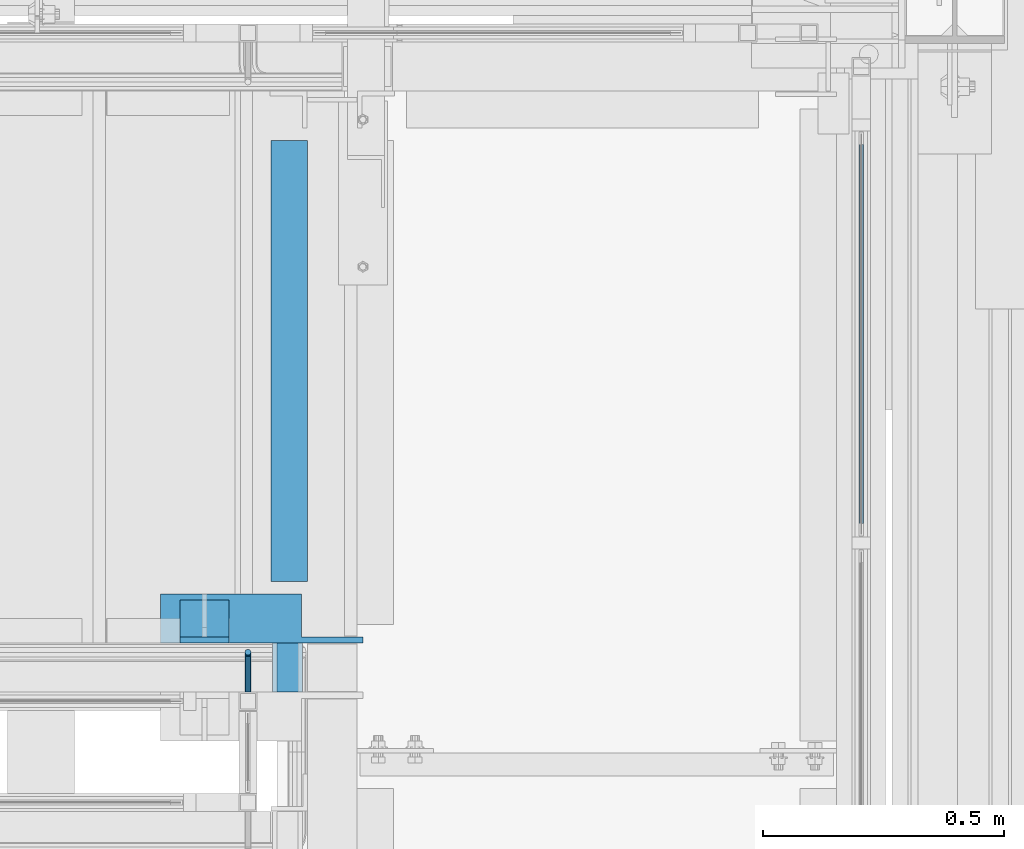
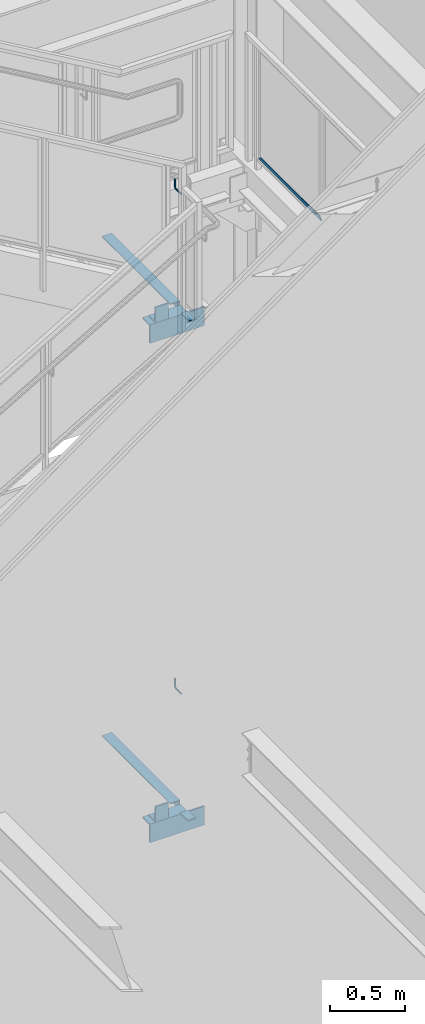
# One storey, part 947 of 1179: 11 beams, 11 elements without a shape of their own.
"""IFC2X3 building model written with IfcOpenShell, lengths in millimetres."""

from ifc_helpers import new_model, si_unit, frame, origin_with_axes, place, context, subcontext, project, spatial, faceted_brep, material, type_object, element, aggregate, save


model = new_model("IFC2X3")

# Units and contexts
model_context = context("Model", 3, precision=1e-05, world=origin_with_axes())
body_context = subcontext(model_context, "Body", "Model", "MODEL_VIEW")
ifc_project = project(units=[si_unit("LENGTHUNIT", "METRE", prefix="MILLI"), si_unit("AREAUNIT", "SQUARE_METRE"), si_unit("VOLUMEUNIT", "CUBIC_METRE"), si_unit("MASSUNIT", "GRAM", prefix="KILO"), si_unit("TIMEUNIT", "SECOND"), si_unit("PLANEANGLEUNIT", "RADIAN"), si_unit("SOLIDANGLEUNIT", "STERADIAN"), si_unit("THERMODYNAMICTEMPERATUREUNIT", "DEGREE_CELSIUS"), si_unit("LUMINOUSINTENSITYUNIT", "LUMEN")], contexts=[model_context])

# Site, building, storey
site_placement = place(None, origin_with_axes())
site = spatial("IfcSite", under=ifc_project, at=site_placement, CompositionType="ELEMENT")
building_placement = place(site_placement, origin_with_axes())
building = spatial("IfcBuilding", under=site, at=building_placement, Name="Undefined", CompositionType="ELEMENT")
storey_placement = place(building_placement, origin_with_axes())
storey = spatial("IfcBuildingStorey", under=building, at=storey_placement, Name="Undefined", CompositionType="ELEMENT", Elevation=0.0)

# Assembly, beam
assembly_1_placement = place(storey_placement, origin_with_axes())
assembly_1 = element("IfcElementAssembly", 1, at=assembly_1_placement, inside=storey, Name="GUARDRAIL", AssemblyPlace="NOTDEFINED", PredefinedType="RIGID_FRAME")
ifc_material_1 = material(Name="STEEL/BUY-OUT")
beam_type_1 = type_object("IfcBeamType", PredefinedType="NOTDEFINED")
beam_1_placement = place(assembly_1_placement, frame((24110.9502052178, 40441.9591242175, 6357.93749909944), z_axis=(0.0, 1.0, 0.0), x_axis=(0.0, 0.0, -1.0)))
beam_1 = element("IfcBeam", 2, at=beam_1_placement, type_object=beam_type_1, material=ifc_material_1, Name="U-EDGE", context=body_context, shape_type="Brep", body=[
    faceted_brep([(-5.45696821063757e-11, -4.76236513509502, -392.906500000157), (22.2249999999613, -4.76236513509502, -415.131500000178), (22.2249999999794, -1.58750000000146, -415.131500000192), (0.0, -1.58750000000146, -392.906500000216), (0.0, 1.58750000000146, -392.906500000216), (25.3999999999969, 1.58750000000146, -418.306499999999), (25.3999999999423, -7.93736513509793, -418.306499999999), (-5.45696821063757e-11, -7.93736513509793, -392.906500000157), (25.3999999999423, -7.93736513509793, 418.306499999999), (-5.45696821063757e-11, -7.93736513509793, 392.906500780409), (-5.45696821063757e-11, -4.76236513509502, 392.906500780409), (22.2249999999613, -4.76236513509502, 415.131500780422), (22.2249999999794, -1.58750000000146, 415.131500780437), (0.0, -1.58750000000146, 392.90650078046), (0.0, 1.58750000000146, 392.90650078046), (25.3999999999969, 1.58750000000146, 418.306499999999)], [[[0, 1, 2, 3, 4, 5, 6, 7]], [[7, 6, 8, 9]], [[0, 7, 9, 10]], [[1, 0, 10, 11]], [[2, 1, 11, 12]], [[3, 2, 12, 13]], [[4, 3, 13, 14]], [[5, 4, 14, 15]], [[6, 5, 15, 8]], [[14, 13, 12, 11, 10, 9, 8, 15]]]),
])
aggregate(assembly_1, [beam_1])

assembly_2_placement = place(storey_placement, origin_with_axes())
assembly_2 = element("IfcElementAssembly", 3, at=assembly_2_placement, inside=storey, Name="GUARDRAIL", AssemblyPlace="NOTDEFINED", PredefinedType="RIGID_FRAME")
ifc_material_2 = material(Name="STEEL/A36")
beam_type_2 = type_object("IfcBeamType", PredefinedType="NOTDEFINED")
beam_2_placement = place(assembly_2_placement, frame((22844.1248872972, 39700.2000007745, 3115.90436315388), z_axis=(0.0, 0.0, 1.0), x_axis=(0.0, 1.0, 0.0)))
beam_2 = element("IfcBeam", 4, at=beam_2_placement, type_object=beam_type_2, material=ifc_material_2, Name="BRACKET", context=body_context, shape_type="Brep", body=[
    faceted_brep([(0.0, 0.0, 6.34999999999991), (0.0, -4.49012806053361, 4.49012806053452), (69.849999425729, -4.49012806053361, 4.49012806053452), (69.849999425729, 0.0, 6.34999999999991), (0.0, 4.49012806053361, 4.49012806053452), (69.849999425729, 4.49012806053361, 4.49012806053452), (0.0, 6.34999999999854, 0.0), (69.849999425729, 6.34999999999854, 0.0), (0.0, 4.49012806053361, -4.49012806053452), (69.849999425729, 4.49012806053361, -4.49012806053452), (0.0, 0.0, -6.34999999999991), (69.849999425729, 0.0, -6.34999999999991), (0.0, -4.49012806053361, -4.49012806053452), (69.849999425729, -4.49012806053361, -4.49012806053452), (0.0, -6.34999999999854, 0.0), (69.849999425729, -6.34999999999854, 0.0), (76.1999993303689, -6.34999999999854, 1.70147734638658), (73.9549353000984, -4.49012806053361, 5.59004231305425), (73.024999330366, 0.0, 7.20073866041639), (73.9549353000984, 4.49012806053361, 5.59004231305425), (76.1999993303689, 6.34999999999854, 1.70147734638658), (78.445063360632, 4.49012806053361, -2.18708762028064), (79.3749993303718, 0.0, -3.79778396764323), (78.445063360632, -4.49012806053361, -2.18708762028064), (84.7370868552753, 4.49012806053361, 4.10493587436031), (87.0401272955278, 4.49012806053361, 12.6999998092651), (88.8999992349927, 0.0, 12.6999998092651), (86.3477832026401, 0.0, 3.17499990462693), (80.8485218886053, 6.34999999999854, 6.34999990462893), (82.5499992349942, 6.34999999999854, 12.6999998092651), (76.9599569219426, 4.49012806053361, 8.59506393489755), (78.0598711744606, 4.49012806053361, 12.6999998092651), (75.3492605745778, 0.0, 9.52499990463093), (76.1999992349956, 0.0, 12.6999998092651), (76.9599569219426, -4.49012806053361, 8.59506393489755), (78.0598711744606, -4.49012806053361, 12.6999998092651), (80.8485218886053, -6.34999999999854, 6.34999990462893), (82.5499992349942, -6.34999999999854, 12.6999998092651), (84.7370868552753, -4.49012806053361, 4.10493587436031), (87.0401272955278, -4.49012806053361, 12.6999998092651), (88.8999992349927, 0.0, 76.2000000000003), (87.0401272955278, -4.49012806053361, 73.5797637174637), (82.5499992349942, -6.34999999999854, 72.4944263126154), (78.0598711744606, -4.49012806053361, 73.5797637174637), (76.1999992349956, 0.0, 76.2000000000003), (78.0598711744606, 4.49012806053361, 78.8202362825368), (82.5499992349942, 6.34999999999854, 79.8943188022276), (87.0401272955278, 4.49012806053361, 78.8202362825368)], [[[0, 1, 2, 3]], [[4, 0, 3, 5]], [[6, 4, 5, 7]], [[8, 6, 7, 9]], [[10, 8, 9, 11]], [[12, 10, 11, 13]], [[1, 0, 4, 6, 8, 10, 12, 14]], [[1, 14, 15, 2]], [[14, 12, 13, 15]], [[2, 15, 16, 17]], [[3, 2, 17, 18]], [[5, 3, 18, 19]], [[7, 5, 19, 20]], [[9, 7, 20, 21]], [[11, 9, 21, 22]], [[13, 11, 22, 23]], [[24, 25, 26, 27]], [[28, 29, 25, 24]], [[30, 31, 29, 28]], [[32, 33, 31, 30]], [[34, 35, 33, 32]], [[36, 37, 35, 34]], [[38, 39, 37, 36]], [[27, 26, 39, 38]], [[22, 27, 38, 23]], [[21, 24, 27, 22]], [[20, 28, 24, 21]], [[19, 30, 28, 20]], [[18, 32, 30, 19]], [[17, 34, 32, 18]], [[16, 36, 34, 17]], [[23, 38, 36, 16]], [[15, 13, 23, 16]], [[39, 26, 40, 41]], [[37, 39, 41, 42]], [[35, 37, 42, 43]], [[33, 35, 43, 44]], [[31, 33, 44, 45]], [[29, 31, 45, 46]], [[25, 29, 46, 47]], [[26, 25, 47, 40]], [[46, 45, 44, 43, 42, 41, 40, 47]]]),
])
aggregate(assembly_2, [beam_2])

assembly_3_placement = place(storey_placement, origin_with_axes())
assembly_3 = element("IfcElementAssembly", 5, at=assembly_3_placement, inside=storey, Name="GUARDRAIL", AssemblyPlace="NOTDEFINED", PredefinedType="RIGID_FRAME")
beam_3_placement = place(assembly_3_placement, frame((22844.1250009048, 39700.2000007796, 7190.75199669734), z_axis=(0.0, 0.0, 1.0), x_axis=(0.0, 1.0, 0.0)))
beam_3 = element("IfcBeam", 6, at=beam_3_placement, type_object=beam_type_2, material=ifc_material_2, Name="BRACKET", context=body_context, shape_type="Brep", body=[
    faceted_brep([(0.0, 0.0, 6.34999999999991), (0.0, -4.49012806053361, 4.49012806053452), (69.849999425729, -4.49012806053361, 4.49012806053452), (69.849999425729, 0.0, 6.34999999999991), (0.0, 4.49012806053361, 4.49012806053452), (69.849999425729, 4.49012806053361, 4.49012806053452), (0.0, 6.34999999999854, 0.0), (69.849999425729, 6.34999999999854, 0.0), (0.0, 4.49012806053361, -4.49012806053452), (69.849999425729, 4.49012806053361, -4.49012806053452), (0.0, 0.0, -6.34999999999991), (69.849999425729, 0.0, -6.34999999999991), (0.0, -4.49012806053361, -4.49012806053452), (69.849999425729, -4.49012806053361, -4.49012806053452), (0.0, -6.34999999999854, 0.0), (69.849999425729, -6.34999999999854, 0.0), (76.1999993303689, -6.34999999999854, 1.70147734638658), (73.9549353000984, -4.49012806053361, 5.59004231305425), (73.024999330366, 0.0, 7.20073866041639), (73.9549353000984, 4.49012806053361, 5.59004231305425), (76.1999993303689, 6.34999999999854, 1.70147734638658), (78.445063360632, 4.49012806053361, -2.18708762028064), (79.3749993303718, 0.0, -3.79778396764323), (78.445063360632, -4.49012806053361, -2.18708762028064), (84.7370868552753, 4.49012806053361, 4.10493587436031), (87.0401272955278, 4.49012806053361, 12.6999998092651), (88.8999992349927, 0.0, 12.6999998092651), (86.3477832026401, 0.0, 3.17499990462693), (80.8485218886053, 6.34999999999854, 6.34999990462893), (82.5499992349942, 6.34999999999854, 12.6999998092651), (76.9599569219426, 4.49012806053361, 8.59506393489755), (78.0598711744606, 4.49012806053361, 12.6999998092651), (75.3492605745778, 0.0, 9.52499990463093), (76.1999992349956, 0.0, 12.6999998092651), (76.9599569219426, -4.49012806053361, 8.59506393489755), (78.0598711744606, -4.49012806053361, 12.6999998092651), (80.8485218886053, -6.34999999999854, 6.34999990462893), (82.5499992349942, -6.34999999999854, 12.6999998092651), (84.7370868552753, -4.49012806053361, 4.10493587436031), (87.0401272955278, -4.49012806053361, 12.6999998092651), (88.8999992349927, 0.0, 76.2000000000003), (87.0401272955278, -4.49012806053361, 73.5797637174637), (82.5499992349942, -6.34999999999854, 72.4944263126154), (78.0598711744606, -4.49012806053361, 73.5797637174637), (76.1999992349956, 0.0, 76.2000000000003), (78.0598711744606, 4.49012806053361, 78.8202362825368), (82.5499992349942, 6.34999999999854, 79.8943188022276), (87.0401272955278, 4.49012806053361, 78.8202362825368)], [[[0, 1, 2, 3]], [[4, 0, 3, 5]], [[6, 4, 5, 7]], [[8, 6, 7, 9]], [[10, 8, 9, 11]], [[12, 10, 11, 13]], [[1, 0, 4, 6, 8, 10, 12, 14]], [[1, 14, 15, 2]], [[14, 12, 13, 15]], [[2, 15, 16, 17]], [[3, 2, 17, 18]], [[5, 3, 18, 19]], [[7, 5, 19, 20]], [[9, 7, 20, 21]], [[11, 9, 21, 22]], [[13, 11, 22, 23]], [[24, 25, 26, 27]], [[28, 29, 25, 24]], [[30, 31, 29, 28]], [[32, 33, 31, 30]], [[34, 35, 33, 32]], [[36, 37, 35, 34]], [[38, 39, 37, 36]], [[27, 26, 39, 38]], [[22, 27, 38, 23]], [[21, 24, 27, 22]], [[20, 28, 24, 21]], [[19, 30, 28, 20]], [[18, 32, 30, 19]], [[17, 34, 32, 18]], [[16, 36, 34, 17]], [[23, 38, 36, 16]], [[15, 13, 23, 16]], [[39, 26, 40, 41]], [[37, 39, 41, 42]], [[35, 37, 42, 43]], [[33, 35, 43, 44]], [[31, 33, 44, 45]], [[29, 31, 45, 46]], [[25, 29, 46, 47]], [[26, 25, 47, 40]], [[46, 45, 44, 43, 42, 41, 40, 47]]]),
])
aggregate(assembly_3, [beam_3])

assembly_4_placement = place(storey_placement, origin_with_axes())
assembly_4 = element("IfcElementAssembly", 7, at=assembly_4_placement, inside=storey, Name="ANGLE", AssemblyPlace="NOTDEFINED", PredefinedType="RIGID_FRAME")
beam_type_3 = type_object("IfcBeamType", Name="L5X3-1/2X1/2", PredefinedType="NOTDEFINED")
beam_4_placement = place(assembly_4_placement, frame((22804.8939505092, 39846.2499999632, 6188.67000099707), z_axis=(0.0, 0.0, 1.0), x_axis=(-1.0, 0.0, 0.0)))
beam_4 = element("IfcBeam", 8, at=beam_4_placement, type_object=beam_type_3, material=ifc_material_2, Name="ANGLE", ObjectType="L5X3-1/2X1/2", context=body_context, shape_type="Brep", body=[
    faceted_brep([(0.0, 44.4499999999971, -63.5), (0.0, 44.4499999999971, 63.5), (101.599999999999, 44.4499999999971, 63.5), (101.599999999999, 44.4499999999971, -63.5), (0.0, 31.75, 63.5), (101.599999999999, 31.75, 63.5), (0.0, 31.75, -50.8000000000002), (101.599999999999, 31.75, -50.8000000000002), (0.0, -44.4499999999971, -50.8000000000002), (101.599999999999, -44.4499999999971, -50.8000000000002), (0.0, -44.4499999999971, -63.5), (101.599999999999, -44.4499999999971, -63.5)], [[[0, 1, 2, 3]], [[1, 4, 5, 2]], [[4, 6, 7, 5]], [[6, 8, 9, 7]], [[8, 10, 11, 9]], [[10, 0, 3, 11]], [[5, 7, 9, 11, 3, 2]], [[10, 8, 6, 4, 1, 0]]]),
])
aggregate(assembly_4, [beam_4])

assembly_5_placement = place(storey_placement, origin_with_axes())
assembly_5 = element("IfcElementAssembly", 9, at=assembly_5_placement, inside=storey, Name="ANGLE", AssemblyPlace="NOTDEFINED", PredefinedType="RIGID_FRAME")
beam_5_placement = place(assembly_5_placement, frame((22804.8939505092, 39846.2499999632, 2115.145312), z_axis=(0.0, 0.0, 1.0), x_axis=(-1.0, 0.0, 0.0)))
beam_5 = element("IfcBeam", 10, at=beam_5_placement, type_object=beam_type_3, material=ifc_material_2, Name="ANGLE", ObjectType="L5X3-1/2X1/2", context=body_context, shape_type="Brep", body=[
    faceted_brep([(0.0, 44.4499999999971, -63.5), (0.0, 44.4499999999971, 63.5), (101.599999999999, 44.4499999999971, 63.5), (101.599999999999, 44.4499999999971, -63.5), (0.0, 31.75, 63.5), (101.599999999999, 31.75, 63.5), (0.0, 31.75, -50.8000000000002), (101.599999999999, 31.75, -50.8000000000002), (0.0, -44.4499999999971, -50.8000000000002), (101.599999999999, -44.4499999999971, -50.8000000000002), (0.0, -44.4499999999971, -63.5), (101.599999999999, -44.4499999999971, -63.5)], [[[0, 1, 2, 3]], [[1, 4, 5, 2]], [[4, 6, 7, 5]], [[6, 8, 9, 7]], [[8, 10, 11, 9]], [[10, 0, 3, 11]], [[5, 7, 9, 11, 3, 2]], [[10, 8, 6, 4, 1, 0]]]),
])
aggregate(assembly_5, [beam_5])

assembly_6_placement = place(storey_placement, origin_with_axes())
assembly_6 = element("IfcElementAssembly", 11, at=assembly_6_placement, inside=storey, Name="ANGLE", AssemblyPlace="NOTDEFINED", PredefinedType="RIGID_FRAME")
beam_type_4 = type_object("IfcBeamType", Name="L6X4X1/2", PredefinedType="NOTDEFINED")
beam_6_placement = place(assembly_6_placement, frame((22663.1500006927, 39852.6000000405, 6048.97000099708), z_axis=(0.0, 0.0, -1.0), x_axis=(1.0, 0.0, 0.0)))
beam_6 = element("IfcBeam", 12, at=beam_6_placement, type_object=beam_type_4, material=ifc_material_2, Name="ANGLE", ObjectType="L6X4X1/2", context=body_context, shape_type="Brep", body=[
    faceted_brep([(292.099999999999, -50.8000000000029, -63.5), (292.099999999999, -50.8000000000029, -76.1999999999998), (292.099999999999, 38.0999999999985, -76.1999999999998), (292.099999999999, 38.0999999999985, -63.5), (419.099999999999, 38.0999999999985, -63.5), (419.099999999999, 38.0999999999985, -76.1999999999998), (0.0, 38.0999999999985, -63.5), (0.0, -50.8000000000029, -63.5), (0.0, -50.8000000000029, -76.1999999999998), (0.0, 50.8000000000029, -76.1999999999998), (419.099999999999, 50.8000000000029, -76.1999999999998), (0.0, 50.8000000000029, 76.1999999999998), (419.099999999999, 50.8000000000029, 76.1999999999998), (0.0, 38.0999999999985, 76.1999999999998), (292.099999999999, 38.0999999999985, 76.1999999999998), (419.099999999999, 38.0999999999985, 76.1999999999998)], [[[0, 1, 2, 3]], [[4, 3, 2, 5]], [[6, 7, 0, 3]], [[7, 8, 1, 0]], [[1, 8, 9, 10, 5, 2]], [[9, 11, 12, 10]], [[8, 7, 6, 13, 11, 9]], [[11, 13, 14, 15, 12]], [[10, 12, 15, 4, 5]], [[14, 13, 6, 3, 4, 15]]]),
])
aggregate(assembly_6, [beam_6])

assembly_7_placement = place(storey_placement, origin_with_axes())
assembly_7 = element("IfcElementAssembly", 13, at=assembly_7_placement, inside=storey, Name="ANGLE", AssemblyPlace="NOTDEFINED", PredefinedType="RIGID_FRAME")
beam_7_placement = place(assembly_7_placement, frame((22663.1500006927, 39852.6000000405, 1975.445312), z_axis=(0.0, 0.0, -1.0), x_axis=(1.0, 0.0, 0.0)))
beam_7 = element("IfcBeam", 14, at=beam_7_placement, type_object=beam_type_4, material=ifc_material_2, Name="ANGLE", ObjectType="L6X4X1/2", context=body_context, shape_type="Brep", body=[
    faceted_brep([(292.099999999999, -50.8000000000029, -63.5), (292.099999999999, -50.8000000000029, -76.1999999999998), (292.099999999999, 38.0999999999985, -76.1999999999998), (292.099999999999, 38.0999999999985, -63.5), (419.099999999999, 38.0999999999985, -63.5), (419.099999999999, 38.0999999999985, -76.1999999999998), (0.0, 38.0999999999985, -63.5), (0.0, -50.8000000000029, -63.5), (0.0, -50.8000000000029, -76.1999999999998), (0.0, 50.8000000000029, -76.1999999999998), (419.099999999999, 50.8000000000029, -76.1999999999998), (0.0, 50.8000000000029, 76.1999999999998), (419.099999999999, 50.8000000000029, 76.1999999999998), (0.0, 38.0999999999985, 76.1999999999998), (292.099999999999, 38.0999999999985, 76.1999999999998), (419.099999999999, 38.0999999999985, 76.1999999999998)], [[[0, 1, 2, 3]], [[4, 3, 2, 5]], [[6, 7, 0, 3]], [[7, 8, 1, 0]], [[1, 8, 9, 10, 5, 2]], [[9, 11, 12, 10]], [[8, 7, 6, 13, 11, 9]], [[11, 13, 14, 15, 12]], [[10, 12, 15, 4, 5]], [[14, 13, 6, 3, 4, 15]]]),
])
aggregate(assembly_7, [beam_7])

assembly_8_placement = place(storey_placement, origin_with_axes())
assembly_8 = element("IfcElementAssembly", 15, at=assembly_8_placement, inside=storey, Name="BEAM", AssemblyPlace="NOTDEFINED", PredefinedType="RIGID_FRAME")
beam_type_5 = type_object("IfcBeamType", Name="L3X3X1/4", PredefinedType="NOTDEFINED")
beam_8_placement = place(assembly_8_placement, frame((22929.8499999835, 39928.800000041, 6099.77000099708), z_axis=(0.0, 0.0, -1.0), x_axis=(0.0, 1.0, 0.0)))
beam_8 = element("IfcBeam", 16, at=beam_8_placement, type_object=beam_type_5, material=ifc_material_2, Name="ANGLE", ObjectType="L3X3X1/4", context=body_context, shape_type="Brep", body=[
    faceted_brep([(0.0, 38.0999999999985, -38.0999999999999), (0.0, 38.0999999999985, 38.0999999999999), (914.399999959271, 38.0999999999985, 38.1000000000004), (914.399999959271, 38.0999999999985, -38.1000000000004), (0.0, 31.75, 38.1000000000004), (914.399999959271, 31.75, 38.1000000000004), (0.0, 31.75, -31.75), (914.399999959271, 31.75, -31.75), (0.0, -38.0999999999985, -31.75), (914.399999959271, -38.0999999999985, -31.75), (0.0, -38.0999999999985, -38.0999999999999), (914.399999959271, -38.0999999999985, -38.1000000000004)], [[[0, 1, 2, 3]], [[1, 4, 5, 2]], [[4, 6, 7, 5]], [[6, 8, 9, 7]], [[8, 10, 11, 9]], [[10, 0, 3, 11]], [[5, 7, 9, 11, 3, 2]], [[10, 8, 6, 4, 1, 0]]]),
])
aggregate(assembly_8, [beam_8])

assembly_9_placement = place(storey_placement, origin_with_axes())
assembly_9 = element("IfcElementAssembly", 17, at=assembly_9_placement, inside=storey, Name="BEAM", AssemblyPlace="NOTDEFINED", PredefinedType="RIGID_FRAME")
beam_9_placement = place(assembly_9_placement, frame((22929.8499998821, 39928.800000041, 2026.245312), z_axis=(0.0, 0.0, -1.0), x_axis=(0.0, 1.0, 0.0)))
beam_9 = element("IfcBeam", 18, at=beam_9_placement, type_object=beam_type_5, material=ifc_material_2, Name="ANGLE", ObjectType="L3X3X1/4", context=body_context, shape_type="Brep", body=[
    faceted_brep([(0.0, 38.0999999999985, -38.0999999999999), (0.0, 38.0999999999985, 38.0999999999999), (914.399999959271, 38.0999999999985, 38.1000000000004), (914.399999959271, 38.0999999999985, -38.1000000000004), (0.0, 31.75, 38.1000000000004), (914.399999959271, 31.75, 38.1000000000004), (0.0, 31.75, -31.75), (914.399999959271, 31.75, -31.75), (0.0, -38.0999999999985, -31.75), (914.399999959271, -38.0999999999985, -31.75), (0.0, -38.0999999999985, -38.0999999999999), (914.399999959271, -38.0999999999985, -38.1000000000004)], [[[0, 1, 2, 3]], [[1, 4, 5, 2]], [[4, 6, 7, 5]], [[6, 8, 9, 7]], [[8, 10, 11, 9]], [[10, 0, 3, 11]], [[5, 7, 9, 11, 3, 2]], [[10, 8, 6, 4, 1, 0]]]),
])
aggregate(assembly_9, [beam_9])

assembly_10_placement = place(storey_placement, origin_with_axes())
assembly_10 = element("IfcElementAssembly", 19, at=assembly_10_placement, inside=storey, Name="STAIR", AssemblyPlace="NOTDEFINED", PredefinedType="RIGID_FRAME")
beam_type_6 = type_object("IfcBeamType", PredefinedType="NOTDEFINED")
beam_10_placement = place(assembly_10_placement, frame((22956.8374997552, 39751.0000000355, 6133.10750099708), z_axis=(0.0, -1.0, 0.0), x_axis=(-1.0, 0.0, 0.0)))
beam_10 = element("IfcBeam", 20, at=beam_10_placement, type_object=beam_type_6, material=ifc_material_2, Name="PLATE", context=body_context, shape_type="Brep", body=[
    faceted_brep([(0.0, 4.76249999999982, -50.7999999999993), (0.0, 4.76249999999982, 50.7999999999993), (52.3874995939332, 4.76249999999982, 50.8000000000029), (52.3874995939332, 4.76249999999982, -50.8000000000029), (0.0, -4.76249999999982, 50.7999999999993), (52.3874995939332, -4.76249999999982, 50.8000000000029), (0.0, -4.76249999999982, -50.7999999999993), (52.3874995939332, -4.76249999999982, -50.8000000000029)], [[[0, 1, 2, 3]], [[1, 4, 5, 2]], [[4, 6, 7, 5]], [[6, 0, 3, 7]], [[5, 7, 3, 2]], [[6, 4, 1, 0]]]),
])
aggregate(assembly_10, [beam_10])

assembly_11_placement = place(storey_placement, origin_with_axes())
assembly_11 = element("IfcElementAssembly", 21, at=assembly_11_placement, inside=storey, Name="STAIR", AssemblyPlace="NOTDEFINED", PredefinedType="RIGID_FRAME")
beam_type_7 = type_object("IfcBeamType", PredefinedType="NOTDEFINED")
beam_11_placement = place(assembly_11_placement, frame((22956.8375000084, 39751.0000000355, 2059.582812), z_axis=(0.0, -1.0, 0.0), x_axis=(-1.0, 0.0, 0.0)))
beam_11 = element("IfcBeam", 22, at=beam_11_placement, type_object=beam_type_7, material=ifc_material_2, Name="PLATE", context=body_context, shape_type="Brep", body=[
    faceted_brep([(0.0, 4.76249999999982, -50.7999999999993), (0.0, 4.76249999999982, 50.7999999999993), (61.9124995939346, 4.76249999999982, 50.8000000000029), (61.9124995939346, 4.76249999999982, -50.8000000000029), (0.0, -4.76249999999982, 50.7999999999993), (61.9124995939346, -4.76249999999982, 50.8000000000029), (0.0, -4.76249999999982, -50.7999999999993), (61.9124995939346, -4.76249999999982, -50.8000000000029)], [[[0, 1, 2, 3]], [[1, 4, 5, 2]], [[4, 6, 7, 5]], [[6, 0, 3, 7]], [[5, 7, 3, 2]], [[6, 4, 1, 0]]]),
])
aggregate(assembly_11, [beam_11])

save(model, "model.ifc")
